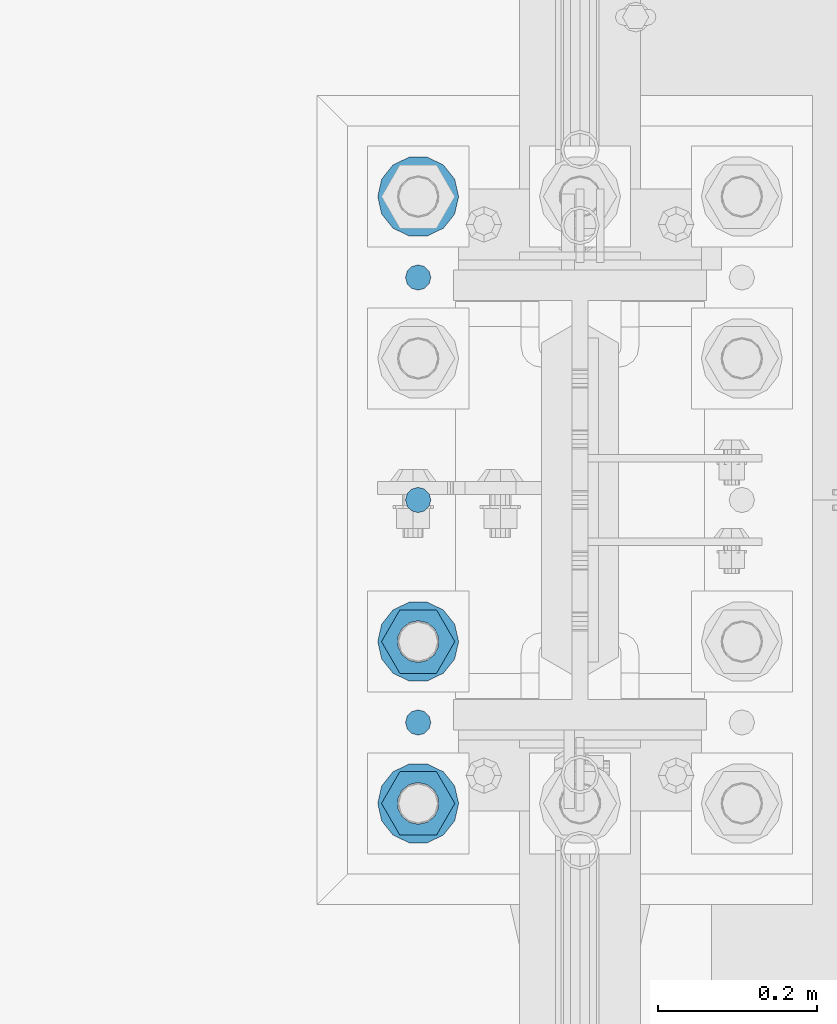
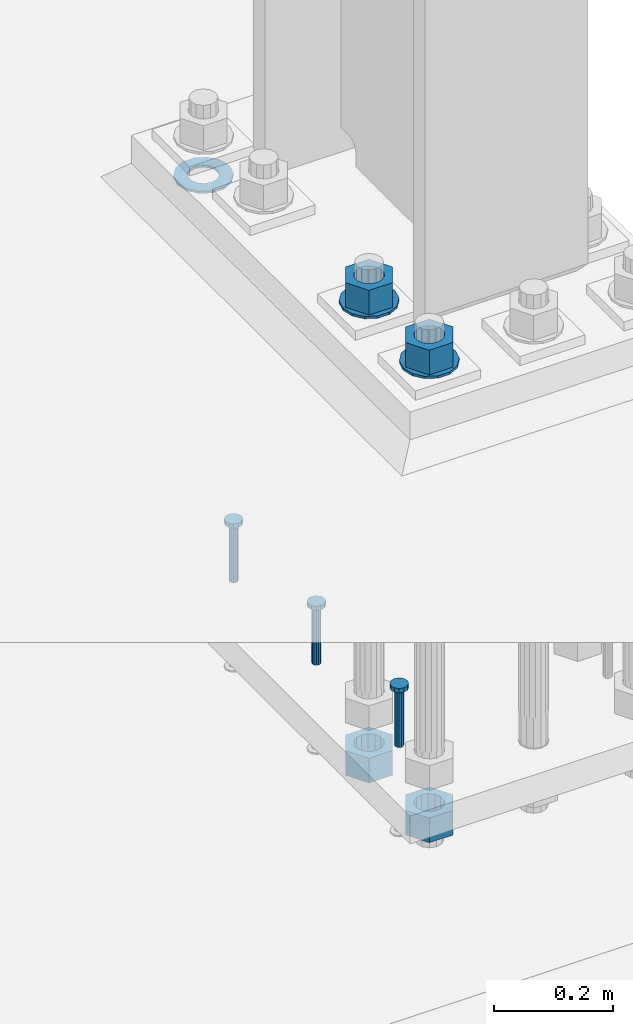
# One storey, part 849 of 1876: 10 columns, 1 element without a shape of its own.
"""IFC2X3 building model written with IfcOpenShell, lengths in millimetres."""

from ifc_helpers import new_model, si_unit, frame, origin_with_axes, place, context, subcontext, project, spatial, faceted_brep, material, type_object, element, aggregate, save


model = new_model("IFC2X3")

# Units and contexts
model_context = context("Model", 3, precision=1e-05, world=origin_with_axes())
body_context = subcontext(model_context, "Body", "Model", "MODEL_VIEW")
ifc_project = project(units=[si_unit("LENGTHUNIT", "METRE", prefix="MILLI"), si_unit("AREAUNIT", "SQUARE_METRE"), si_unit("VOLUMEUNIT", "CUBIC_METRE"), si_unit("MASSUNIT", "GRAM", prefix="KILO"), si_unit("TIMEUNIT", "SECOND"), si_unit("PLANEANGLEUNIT", "RADIAN"), si_unit("SOLIDANGLEUNIT", "STERADIAN"), si_unit("THERMODYNAMICTEMPERATUREUNIT", "DEGREE_CELSIUS"), si_unit("LUMINOUSINTENSITYUNIT", "LUMEN")], contexts=[model_context])

# Site, building, storey
site_placement = place(None, origin_with_axes())
site = spatial("IfcSite", under=ifc_project, at=site_placement, CompositionType="ELEMENT")
building_placement = place(site_placement, origin_with_axes())
building = spatial("IfcBuilding", under=site, at=building_placement, Name="Undefined", CompositionType="ELEMENT")
storey_placement = place(building_placement, origin_with_axes())
storey = spatial("IfcBuildingStorey", under=building, at=storey_placement, Name="Undefined", CompositionType="ELEMENT", Elevation=0.0)

# Assembly, columns
assembly_placement = place(storey_placement, origin_with_axes())
assembly = element("IfcElementAssembly", 1, at=assembly_placement, inside=storey, Name="TEMPLATE", AssemblyPlace="NOTDEFINED", PredefinedType="RIGID_FRAME")
ifc_material_1 = material(Name="STEEL/F436")
column_type_1 = type_object("IfcColumnType", Name="2_WASHER", PredefinedType="NOTDEFINED")
column_1_placement = place(assembly_placement, frame((7416.8, 8001.0, 38.1), z_axis=(0.0, -1.0, 0.0), x_axis=(0.0, 0.0, -1.0)))
column_1 = element("IfcColumn", 2, at=column_1_placement, type_object=column_type_1, material=ifc_material_1, Name="WASHER", ObjectType="2_WASHER", context=body_context, shape_type="Brep", body=[
    faceted_brep([(0.0, -50.7999992370605, 9.09494701772928e-13), (0.0, -45.7692178020588, -22.0412936161442), (4.7625, -45.7692178020588, -22.0412936161442), (4.7625, -50.7999992370605, 9.09494701772928e-13), (0.0, -31.6732814587394, -39.7170387128856), (4.7625, -31.6732814587394, -39.7170387128856), (0.0, -11.3040632752118, -49.5263371950259), (4.7625, -11.3040632752118, -49.5263371950259), (0.0, 11.30406327521, -49.5263371950264), (4.7625, 11.30406327521, -49.5263371950264), (0.0, 31.6732814587385, -39.7170387128867), (4.7625, 31.6732814587385, -39.7170387128867), (0.0, 45.7692178020579, -22.041293616146), (4.7625, 45.7692178020579, -22.041293616146), (0.0, 50.7999992370605, -9.09494701772928e-13), (4.7625, 50.7999992370605, -9.09494701772928e-13), (0.0, 45.7692178020588, 22.0412936161442), (4.7625, 45.7692178020588, 22.0412936161442), (0.0, 31.6732814587394, 39.7170387128856), (4.7625, 31.6732814587394, 39.7170387128856), (0.0, 11.3040632752118, 49.5263371950259), (4.7625, 11.3040632752118, 49.5263371950259), (0.0, -11.30406327521, 49.5263371950264), (4.7625, -11.30406327521, 49.5263371950264), (0.0, -31.6732814587385, 39.7170387128867), (4.7625, -31.6732814587385, 39.7170387128867), (0.0, -45.7692178020579, 22.041293616146), (4.7625, -45.7692178020579, 22.041293616146), (0.0, 0.0, 26.9869995117188), (0.0, 11.7093983825444, 24.3146012721213), (4.7625, 11.7093983825444, 24.3146012721213), (4.7625, 0.0, 26.9869995117188), (0.0, 21.0996520289491, 16.8262864224157), (4.7625, 21.0996520289491, 16.8262864224157), (0.0, 26.3108629296712, 6.00524193584533), (4.7625, 26.3108629296712, 6.00524193584533), (0.0, 26.3108629296712, -6.00524193584533), (4.7625, 26.3108629296712, -6.00524193584533), (0.0, 21.0996520289491, -16.8262864224157), (4.7625, 21.0996520289491, -16.8262864224157), (0.0, 11.7093983825444, -24.3146012721213), (4.7625, 11.7093983825444, -24.3146012721213), (0.0, 0.0, -26.9869995117188), (4.7625, 0.0, -26.9869995117188), (0.0, -11.7093983825444, -24.3146012721213), (4.7625, -11.7093983825444, -24.3146012721213), (0.0, -21.0996520289491, -16.8262864224157), (4.7625, -21.0996520289491, -16.8262864224157), (0.0, -26.3108629296712, -6.00524193584533), (4.7625, -26.3108629296712, -6.00524193584533), (0.0, -26.3108629296712, 6.00524193584533), (4.7625, -26.3108629296712, 6.00524193584533), (0.0, -21.0996520289491, 16.8262864224157), (4.7625, -21.0996520289491, 16.8262864224157), (0.0, -11.7093983825444, 24.3146012721213), (4.7625, -11.7093983825444, 24.3146012721213)], [[[0, 1, 2, 3]], [[1, 4, 5, 2]], [[4, 6, 7, 5]], [[6, 8, 9, 7]], [[8, 10, 11, 9]], [[10, 12, 13, 11]], [[12, 14, 15, 13]], [[14, 16, 17, 15]], [[16, 18, 19, 17]], [[18, 20, 21, 19]], [[20, 22, 23, 21]], [[22, 24, 25, 23]], [[24, 26, 27, 25]], [[26, 0, 3, 27]], [[28, 29, 30, 31]], [[29, 32, 33, 30]], [[32, 34, 35, 33]], [[34, 36, 37, 35]], [[36, 38, 39, 37]], [[38, 40, 41, 39]], [[40, 42, 43, 41]], [[42, 44, 45, 43]], [[44, 46, 47, 45]], [[46, 48, 49, 47]], [[48, 50, 51, 49]], [[50, 52, 53, 51]], [[52, 54, 55, 53]], [[54, 28, 31, 55]], [[5, 7, 9, 11, 13, 15, 17, 19, 21, 23, 25, 27, 3, 2], [33, 35, 37, 39, 41, 43, 45, 47, 49, 51, 53, 55, 31, 30]], [[26, 24, 22, 20, 18, 16, 14, 12, 10, 8, 6, 4, 1, 0], [54, 52, 50, 48, 46, 44, 42, 40, 38, 36, 34, 32, 29, 28]]]),
])
column_2_placement = place(assembly_placement, frame((7416.8, 7239.0, 119.0625), z_axis=(0.0, -1.0, 0.0), x_axis=(0.0, 0.0, -1.0)))
column_2 = element("IfcColumn", 3, at=column_2_placement, type_object=column_type_1, material=ifc_material_1, Name="WASHER", ObjectType="2_WASHER", context=body_context, shape_type="Brep", body=[
    faceted_brep([(0.0, -50.7999992370605, 9.09494701772928e-13), (0.0, -45.7692178020588, -22.0412936161442), (4.7625, -45.7692178020588, -22.0412936161442), (4.7625, -50.7999992370605, 9.09494701772928e-13), (0.0, -31.6732814587394, -39.7170387128856), (4.7625, -31.6732814587394, -39.7170387128856), (0.0, -11.3040632752118, -49.5263371950259), (4.7625, -11.3040632752118, -49.5263371950259), (0.0, 11.30406327521, -49.5263371950264), (4.7625, 11.30406327521, -49.5263371950264), (0.0, 31.6732814587385, -39.7170387128867), (4.7625, 31.6732814587385, -39.7170387128867), (0.0, 45.7692178020579, -22.041293616146), (4.7625, 45.7692178020579, -22.041293616146), (0.0, 50.7999992370605, -9.09494701772928e-13), (4.7625, 50.7999992370605, -9.09494701772928e-13), (0.0, 45.7692178020588, 22.0412936161442), (4.7625, 45.7692178020588, 22.0412936161442), (0.0, 31.6732814587394, 39.7170387128856), (4.7625, 31.6732814587394, 39.7170387128856), (0.0, 11.3040632752118, 49.5263371950259), (4.7625, 11.3040632752118, 49.5263371950259), (0.0, -11.30406327521, 49.5263371950264), (4.7625, -11.30406327521, 49.5263371950264), (0.0, -31.6732814587385, 39.7170387128867), (4.7625, -31.6732814587385, 39.7170387128867), (0.0, -45.7692178020579, 22.041293616146), (4.7625, -45.7692178020579, 22.041293616146), (0.0, 0.0, 26.9869995117188), (0.0, 11.7093983825444, 24.3146012721213), (4.7625, 11.7093983825444, 24.3146012721213), (4.7625, 0.0, 26.9869995117188), (0.0, 21.0996520289491, 16.8262864224157), (4.7625, 21.0996520289491, 16.8262864224157), (0.0, 26.3108629296712, 6.00524193584533), (4.7625, 26.3108629296712, 6.00524193584533), (0.0, 26.3108629296712, -6.00524193584533), (4.7625, 26.3108629296712, -6.00524193584533), (0.0, 21.0996520289491, -16.8262864224157), (4.7625, 21.0996520289491, -16.8262864224157), (0.0, 11.7093983825444, -24.3146012721213), (4.7625, 11.7093983825444, -24.3146012721213), (0.0, 0.0, -26.9869995117188), (4.7625, 0.0, -26.9869995117188), (0.0, -11.7093983825444, -24.3146012721213), (4.7625, -11.7093983825444, -24.3146012721213), (0.0, -21.0996520289491, -16.8262864224157), (4.7625, -21.0996520289491, -16.8262864224157), (0.0, -26.3108629296712, -6.00524193584533), (4.7625, -26.3108629296712, -6.00524193584533), (0.0, -26.3108629296712, 6.00524193584533), (4.7625, -26.3108629296712, 6.00524193584533), (0.0, -21.0996520289491, 16.8262864224157), (4.7625, -21.0996520289491, 16.8262864224157), (0.0, -11.7093983825444, 24.3146012721213), (4.7625, -11.7093983825444, 24.3146012721213)], [[[0, 1, 2, 3]], [[1, 4, 5, 2]], [[4, 6, 7, 5]], [[6, 8, 9, 7]], [[8, 10, 11, 9]], [[10, 12, 13, 11]], [[12, 14, 15, 13]], [[14, 16, 17, 15]], [[16, 18, 19, 17]], [[18, 20, 21, 19]], [[20, 22, 23, 21]], [[22, 24, 25, 23]], [[24, 26, 27, 25]], [[26, 0, 3, 27]], [[28, 29, 30, 31]], [[29, 32, 33, 30]], [[32, 34, 35, 33]], [[34, 36, 37, 35]], [[36, 38, 39, 37]], [[38, 40, 41, 39]], [[40, 42, 43, 41]], [[42, 44, 45, 43]], [[44, 46, 47, 45]], [[46, 48, 49, 47]], [[48, 50, 51, 49]], [[50, 52, 53, 51]], [[52, 54, 55, 53]], [[54, 28, 31, 55]], [[5, 7, 9, 11, 13, 15, 17, 19, 21, 23, 25, 27, 3, 2], [33, 35, 37, 39, 41, 43, 45, 47, 49, 51, 53, 55, 31, 30]], [[26, 24, 22, 20, 18, 16, 14, 12, 10, 8, 6, 4, 1, 0], [54, 52, 50, 48, 46, 44, 42, 40, 38, 36, 34, 32, 29, 28]]]),
])
column_3_placement = place(assembly_placement, frame((7416.8, 7442.2, 119.0625), z_axis=(0.0, -1.0, 0.0), x_axis=(0.0, 0.0, -1.0)))
column_3 = element("IfcColumn", 4, at=column_3_placement, type_object=column_type_1, material=ifc_material_1, Name="WASHER", ObjectType="2_WASHER", context=body_context, shape_type="Brep", body=[
    faceted_brep([(0.0, -50.7999992370605, 9.09494701772928e-13), (0.0, -45.7692178020588, -22.0412936161442), (4.7625, -45.7692178020588, -22.0412936161442), (4.7625, -50.7999992370605, 9.09494701772928e-13), (0.0, -31.6732814587394, -39.7170387128856), (4.7625, -31.6732814587394, -39.7170387128856), (0.0, -11.3040632752118, -49.5263371950259), (4.7625, -11.3040632752118, -49.5263371950259), (0.0, 11.30406327521, -49.5263371950264), (4.7625, 11.30406327521, -49.5263371950264), (0.0, 31.6732814587385, -39.7170387128867), (4.7625, 31.6732814587385, -39.7170387128867), (0.0, 45.7692178020579, -22.041293616146), (4.7625, 45.7692178020579, -22.041293616146), (0.0, 50.7999992370605, -9.09494701772928e-13), (4.7625, 50.7999992370605, -9.09494701772928e-13), (0.0, 45.7692178020588, 22.0412936161442), (4.7625, 45.7692178020588, 22.0412936161442), (0.0, 31.6732814587394, 39.7170387128856), (4.7625, 31.6732814587394, 39.7170387128856), (0.0, 11.3040632752118, 49.5263371950259), (4.7625, 11.3040632752118, 49.5263371950259), (0.0, -11.30406327521, 49.5263371950264), (4.7625, -11.30406327521, 49.5263371950264), (0.0, -31.6732814587385, 39.7170387128867), (4.7625, -31.6732814587385, 39.7170387128867), (0.0, -45.7692178020579, 22.041293616146), (4.7625, -45.7692178020579, 22.041293616146), (0.0, 0.0, 26.9869995117188), (0.0, 11.7093983825444, 24.3146012721213), (4.7625, 11.7093983825444, 24.3146012721213), (4.7625, 0.0, 26.9869995117188), (0.0, 21.0996520289491, 16.8262864224157), (4.7625, 21.0996520289491, 16.8262864224157), (0.0, 26.3108629296712, 6.00524193584533), (4.7625, 26.3108629296712, 6.00524193584533), (0.0, 26.3108629296712, -6.00524193584533), (4.7625, 26.3108629296712, -6.00524193584533), (0.0, 21.0996520289491, -16.8262864224157), (4.7625, 21.0996520289491, -16.8262864224157), (0.0, 11.7093983825444, -24.3146012721213), (4.7625, 11.7093983825444, -24.3146012721213), (0.0, 0.0, -26.9869995117188), (4.7625, 0.0, -26.9869995117188), (0.0, -11.7093983825444, -24.3146012721213), (4.7625, -11.7093983825444, -24.3146012721213), (0.0, -21.0996520289491, -16.8262864224157), (4.7625, -21.0996520289491, -16.8262864224157), (0.0, -26.3108629296712, -6.00524193584533), (4.7625, -26.3108629296712, -6.00524193584533), (0.0, -26.3108629296712, 6.00524193584533), (4.7625, -26.3108629296712, 6.00524193584533), (0.0, -21.0996520289491, 16.8262864224157), (4.7625, -21.0996520289491, 16.8262864224157), (0.0, -11.7093983825444, 24.3146012721213), (4.7625, -11.7093983825444, 24.3146012721213)], [[[0, 1, 2, 3]], [[1, 4, 5, 2]], [[4, 6, 7, 5]], [[6, 8, 9, 7]], [[8, 10, 11, 9]], [[10, 12, 13, 11]], [[12, 14, 15, 13]], [[14, 16, 17, 15]], [[16, 18, 19, 17]], [[18, 20, 21, 19]], [[20, 22, 23, 21]], [[22, 24, 25, 23]], [[24, 26, 27, 25]], [[26, 0, 3, 27]], [[28, 29, 30, 31]], [[29, 32, 33, 30]], [[32, 34, 35, 33]], [[34, 36, 37, 35]], [[36, 38, 39, 37]], [[38, 40, 41, 39]], [[40, 42, 43, 41]], [[42, 44, 45, 43]], [[44, 46, 47, 45]], [[46, 48, 49, 47]], [[48, 50, 51, 49]], [[50, 52, 53, 51]], [[52, 54, 55, 53]], [[54, 28, 31, 55]], [[5, 7, 9, 11, 13, 15, 17, 19, 21, 23, 25, 27, 3, 2], [33, 35, 37, 39, 41, 43, 45, 47, 49, 51, 53, 55, 31, 30]], [[26, 24, 22, 20, 18, 16, 14, 12, 10, 8, 6, 4, 1, 0], [54, 52, 50, 48, 46, 44, 42, 40, 38, 36, 34, 32, 29, 28]]]),
])
ifc_material_2 = material(Name="STEEL/A108")
column_type_2 = type_object("IfcColumnType", Name="5/8-DIA_HEADED ANCHOR STUD", PredefinedType="NOTDEFINED")
column_4_placement = place(assembly_placement, frame((7416.8, 7899.4, -736.6), z_axis=(1.0, 0.0, 0.0), x_axis=(0.0, 0.0, 1.0)))
column_4 = element("IfcColumn", 5, at=column_4_placement, type_object=column_type_2, material=ifc_material_2, Name="HEADED ANCHOR STUD", ObjectType="5/8-DIA_HEADED ANCHOR STUD", context=body_context, shape_type="Brep", body=[
    faceted_brep([(0.0, -7.94000005722046, 0.0), (0.0, -6.86999988555908, -3.97000002861023), (116.84, -6.86999988555908, -3.97000002861023), (116.84, -7.94000005722046, 0.0), (0.0, -3.97000002861023, -6.86999988555908), (116.84, -3.97000002861023, -6.86999988555908), (0.0, 0.0, -7.94000005722046), (116.84, 0.0, -7.94000005722046), (0.0, 3.97000002861023, -6.86999988555908), (116.84, 3.97000002861023, -6.86999988555908), (0.0, 6.86999988555908, -3.97000002861023), (116.84, 6.86999988555908, -3.97000002861023), (0.0, 7.94000005722046, 0.0), (116.84, 7.94000005722046, 0.0), (0.0, 6.86999988555908, 3.97000002861023), (116.84, 6.86999988555908, 3.97000002861023), (0.0, 3.97000002861023, 6.86999988555908), (116.84, 3.97000002861023, 6.86999988555908), (0.0, 0.0, 7.94000005722046), (116.84, 0.0, 7.94000005722046), (0.0, -3.97000002861023, 6.86999988555908), (116.84, -3.97000002861023, 6.86999988555908), (0.0, -6.86999988555908, 3.97000002861023), (116.84, -6.86999988555908, 3.97000002861023), (118.11, -13.75, -7.94000005722046), (118.11, -15.8800001144409, 0.0), (118.11, -7.94000005722046, -13.75), (118.11, 0.0, -15.8800001144409), (118.11, 7.94000005722046, -13.75), (118.11, 13.75, -7.94000005722046), (118.11, 15.8800001144409, 0.0), (118.11, 13.75, 7.94000005722046), (118.11, 7.94000005722046, 13.75), (118.11, 0.0, 15.8800001144409), (118.11, -7.94000005722046, 13.75), (118.11, -13.75, 7.94000005722046), (127.0, -13.75, -7.94000005722046), (127.0, -15.8800001144409, 0.0), (127.0, -7.94000005722046, -13.75), (127.0, 0.0, -15.8800001144409), (127.0, 7.94000005722046, -13.75), (127.0, 13.75, -7.94000005722046), (127.0, 15.8800001144409, 0.0), (127.0, 13.75, 7.94000005722046), (127.0, 7.94000005722046, 13.75), (127.0, 0.0, 15.8800001144409), (127.0, -7.94000005722046, 13.75), (127.0, -13.75, 7.94000005722046)], [[[0, 1, 2, 3]], [[1, 4, 5, 2]], [[4, 6, 7, 5]], [[6, 8, 9, 7]], [[8, 10, 11, 9]], [[10, 12, 13, 11]], [[12, 14, 15, 13]], [[14, 16, 17, 15]], [[16, 18, 19, 17]], [[18, 20, 21, 19]], [[20, 22, 23, 21]], [[22, 0, 3, 23]], [[22, 20, 18, 16, 14, 12, 10, 8, 6, 4, 1, 0]], [[3, 2, 24, 25]], [[2, 5, 26, 24]], [[5, 7, 27, 26]], [[7, 9, 28, 27]], [[9, 11, 29, 28]], [[11, 13, 30, 29]], [[13, 15, 31, 30]], [[15, 17, 32, 31]], [[17, 19, 33, 32]], [[19, 21, 34, 33]], [[21, 23, 35, 34]], [[23, 3, 25, 35]], [[25, 24, 36, 37]], [[24, 26, 38, 36]], [[26, 27, 39, 38]], [[27, 28, 40, 39]], [[28, 29, 41, 40]], [[29, 30, 42, 41]], [[30, 31, 43, 42]], [[31, 32, 44, 43]], [[32, 33, 45, 44]], [[33, 34, 46, 45]], [[34, 35, 47, 46]], [[35, 25, 37, 47]], [[38, 39, 40, 41, 42, 43, 44, 45, 46, 47, 37, 36]]]),
])
column_5_placement = place(assembly_placement, frame((7416.8, 7340.6, -736.6), z_axis=(1.0, 0.0, 0.0), x_axis=(0.0, 0.0, 1.0)))
column_5 = element("IfcColumn", 6, at=column_5_placement, type_object=column_type_2, material=ifc_material_2, Name="HEADED ANCHOR STUD", ObjectType="5/8-DIA_HEADED ANCHOR STUD", context=body_context, shape_type="Brep", body=[
    faceted_brep([(0.0, -7.94000005722046, 0.0), (0.0, -6.86999988555908, -3.97000002861023), (116.84, -6.86999988555908, -3.97000002861023), (116.84, -7.94000005722046, 0.0), (0.0, -3.97000002861023, -6.86999988555908), (116.84, -3.97000002861023, -6.86999988555908), (0.0, 0.0, -7.94000005722046), (116.84, 0.0, -7.94000005722046), (0.0, 3.97000002861023, -6.86999988555908), (116.84, 3.97000002861023, -6.86999988555908), (0.0, 6.86999988555908, -3.97000002861023), (116.84, 6.86999988555908, -3.97000002861023), (0.0, 7.94000005722046, 0.0), (116.84, 7.94000005722046, 0.0), (0.0, 6.86999988555908, 3.97000002861023), (116.84, 6.86999988555908, 3.97000002861023), (0.0, 3.97000002861023, 6.86999988555908), (116.84, 3.97000002861023, 6.86999988555908), (0.0, 0.0, 7.94000005722046), (116.84, 0.0, 7.94000005722046), (0.0, -3.97000002861023, 6.86999988555908), (116.84, -3.97000002861023, 6.86999988555908), (0.0, -6.86999988555908, 3.97000002861023), (116.84, -6.86999988555908, 3.97000002861023), (118.11, -13.75, -7.94000005722046), (118.11, -15.8800001144409, 0.0), (118.11, -7.94000005722046, -13.75), (118.11, 0.0, -15.8800001144409), (118.11, 7.94000005722046, -13.75), (118.11, 13.75, -7.94000005722046), (118.11, 15.8800001144409, 0.0), (118.11, 13.75, 7.94000005722046), (118.11, 7.94000005722046, 13.75), (118.11, 0.0, 15.8800001144409), (118.11, -7.94000005722046, 13.75), (118.11, -13.75, 7.94000005722046), (127.0, -13.75, -7.94000005722046), (127.0, -15.8800001144409, 0.0), (127.0, -7.94000005722046, -13.75), (127.0, 0.0, -15.8800001144409), (127.0, 7.94000005722046, -13.75), (127.0, 13.75, -7.94000005722046), (127.0, 15.8800001144409, 0.0), (127.0, 13.75, 7.94000005722046), (127.0, 7.94000005722046, 13.75), (127.0, 0.0, 15.8800001144409), (127.0, -7.94000005722046, 13.75), (127.0, -13.75, 7.94000005722046)], [[[0, 1, 2, 3]], [[1, 4, 5, 2]], [[4, 6, 7, 5]], [[6, 8, 9, 7]], [[8, 10, 11, 9]], [[10, 12, 13, 11]], [[12, 14, 15, 13]], [[14, 16, 17, 15]], [[16, 18, 19, 17]], [[18, 20, 21, 19]], [[20, 22, 23, 21]], [[22, 0, 3, 23]], [[22, 20, 18, 16, 14, 12, 10, 8, 6, 4, 1, 0]], [[3, 2, 24, 25]], [[2, 5, 26, 24]], [[5, 7, 27, 26]], [[7, 9, 28, 27]], [[9, 11, 29, 28]], [[11, 13, 30, 29]], [[13, 15, 31, 30]], [[15, 17, 32, 31]], [[17, 19, 33, 32]], [[19, 21, 34, 33]], [[21, 23, 35, 34]], [[23, 3, 25, 35]], [[25, 24, 36, 37]], [[24, 26, 38, 36]], [[26, 27, 39, 38]], [[27, 28, 40, 39]], [[28, 29, 41, 40]], [[29, 30, 42, 41]], [[30, 31, 43, 42]], [[31, 32, 44, 43]], [[32, 33, 45, 44]], [[33, 34, 46, 45]], [[34, 35, 47, 46]], [[35, 25, 37, 47]], [[38, 39, 40, 41, 42, 43, 44, 45, 46, 47, 37, 36]]]),
])
column_6_placement = place(assembly_placement, frame((7416.8, 7620.0, -736.6), z_axis=(1.0, 0.0, 0.0), x_axis=(0.0, 0.0, 1.0)))
column_6 = element("IfcColumn", 7, at=column_6_placement, type_object=column_type_2, material=ifc_material_2, Name="HEADED ANCHOR STUD", ObjectType="5/8-DIA_HEADED ANCHOR STUD", context=body_context, shape_type="Brep", body=[
    faceted_brep([(0.0, -7.94000005722046, 0.0), (0.0, -6.86999988555908, -3.97000002861023), (116.84, -6.86999988555908, -3.97000002861023), (116.84, -7.94000005722046, 0.0), (0.0, -3.97000002861023, -6.86999988555908), (116.84, -3.97000002861023, -6.86999988555908), (0.0, 0.0, -7.94000005722046), (116.84, 0.0, -7.94000005722046), (0.0, 3.97000002861023, -6.86999988555908), (116.84, 3.97000002861023, -6.86999988555908), (0.0, 6.86999988555908, -3.97000002861023), (116.84, 6.86999988555908, -3.97000002861023), (0.0, 7.94000005722046, 0.0), (116.84, 7.94000005722046, 0.0), (0.0, 6.86999988555908, 3.97000002861023), (116.84, 6.86999988555908, 3.97000002861023), (0.0, 3.97000002861023, 6.86999988555908), (116.84, 3.97000002861023, 6.86999988555908), (0.0, 0.0, 7.94000005722046), (116.84, 0.0, 7.94000005722046), (0.0, -3.97000002861023, 6.86999988555908), (116.84, -3.97000002861023, 6.86999988555908), (0.0, -6.86999988555908, 3.97000002861023), (116.84, -6.86999988555908, 3.97000002861023), (118.11, -13.75, -7.94000005722046), (118.11, -15.8800001144409, 0.0), (118.11, -7.94000005722046, -13.75), (118.11, 0.0, -15.8800001144409), (118.11, 7.94000005722046, -13.75), (118.11, 13.75, -7.94000005722046), (118.11, 15.8800001144409, 0.0), (118.11, 13.75, 7.94000005722046), (118.11, 7.94000005722046, 13.75), (118.11, 0.0, 15.8800001144409), (118.11, -7.94000005722046, 13.75), (118.11, -13.75, 7.94000005722046), (127.0, -13.75, -7.94000005722046), (127.0, -15.8800001144409, 0.0), (127.0, -7.94000005722046, -13.75), (127.0, 0.0, -15.8800001144409), (127.0, 7.94000005722046, -13.75), (127.0, 13.75, -7.94000005722046), (127.0, 15.8800001144409, 0.0), (127.0, 13.75, 7.94000005722046), (127.0, 7.94000005722046, 13.75), (127.0, 0.0, 15.8800001144409), (127.0, -7.94000005722046, 13.75), (127.0, -13.75, 7.94000005722046)], [[[0, 1, 2, 3]], [[1, 4, 5, 2]], [[4, 6, 7, 5]], [[6, 8, 9, 7]], [[8, 10, 11, 9]], [[10, 12, 13, 11]], [[12, 14, 15, 13]], [[14, 16, 17, 15]], [[16, 18, 19, 17]], [[18, 20, 21, 19]], [[20, 22, 23, 21]], [[22, 0, 3, 23]], [[22, 20, 18, 16, 14, 12, 10, 8, 6, 4, 1, 0]], [[3, 2, 24, 25]], [[2, 5, 26, 24]], [[5, 7, 27, 26]], [[7, 9, 28, 27]], [[9, 11, 29, 28]], [[11, 13, 30, 29]], [[13, 15, 31, 30]], [[15, 17, 32, 31]], [[17, 19, 33, 32]], [[19, 21, 34, 33]], [[21, 23, 35, 34]], [[23, 3, 25, 35]], [[25, 24, 36, 37]], [[24, 26, 38, 36]], [[26, 27, 39, 38]], [[27, 28, 40, 39]], [[28, 29, 41, 40]], [[29, 30, 42, 41]], [[30, 31, 43, 42]], [[31, 32, 44, 43]], [[32, 33, 45, 44]], [[33, 34, 46, 45]], [[34, 35, 47, 46]], [[35, 25, 37, 47]], [[38, 39, 40, 41, 42, 43, 44, 45, 46, 47, 37, 36]]]),
])
ifc_material_3 = material(Name="STEEL/A563")
column_type_3 = type_object("IfcColumnType", Name="2_HEAVY_HEX_NUT", PredefinedType="NOTDEFINED")
column_7_placement = place(assembly_placement, frame((7416.8, 7239.0, 169.8625), z_axis=(0.0, -1.0, 0.0), x_axis=(0.0, 0.0, -1.0)))
column_7 = element("IfcColumn", 8, at=column_7_placement, type_object=column_type_3, material=ifc_material_3, Name="NUT", ObjectType="2_HEAVY_HEX_NUT", context=body_context, shape_type="Brep", body=[
    faceted_brep([(0.0, -46.0369987487793, 9.09494701772928e-13), (0.0, -23.0184993743896, -39.869213104248), (50.8, -23.0184993743896, -39.869213104248), (50.8, -46.0369987487793, 9.09494701772928e-13), (0.0, 23.0184993743896, -39.869213104248), (50.8, 23.0184993743896, -39.869213104248), (0.0, 46.0369987487793, -9.09494701772928e-13), (50.8, 46.0369987487793, -9.09494701772928e-13), (0.0, 23.0184993743896, 39.869213104248), (50.8, 23.0184993743896, 39.869213104248), (0.0, -23.0184993743896, 39.869213104248), (50.8, -23.0184993743896, 39.869213104248), (0.0, 0.0, 26.1940002441406), (0.0, 11.3650617044514, 23.5999013092769), (50.8, 11.3650617044513, 23.5999013092771), (50.8, 0.0, 26.1940002441406), (0.0, 20.4791109456437, 16.3316083006703), (50.8, 20.4791109456439, 16.3316083006703), (0.0, 25.5370200498346, 5.82867859874477), (50.8, 25.5370200498343, 5.82867859874455), (0.0, 25.5370200498346, -5.82867859874477), (50.8, 25.5370200498343, -5.82867859874455), (0.0, 20.4791109456437, -16.3316083006703), (50.8, 20.4791109456439, -16.3316083006703), (0.0, 11.3650617044514, -23.5999013092769), (50.8, 11.3650617044514, -23.5999013092771), (0.0, 0.0, -26.1940002441406), (50.8, 0.0, -26.1940002441406), (0.0, -11.3650617044514, -23.5999013092769), (50.8, -11.3650617044513, -23.5999013092771), (0.0, -20.4791109456437, -16.3316083006703), (50.8, -20.4791109456439, -16.3316083006703), (0.0, -25.5370200498346, -5.82867859874477), (50.8, -25.5370200498343, -5.82867859874455), (0.0, -25.5370200498346, 5.82867859874477), (50.8, -25.5370200498343, 5.82867859874455), (0.0, -20.4791109456437, 16.3316083006703), (50.8, -20.4791109456439, 16.3316083006703), (0.0, -11.3650617044514, 23.5999013092769), (50.8, -11.3650617044514, 23.5999013092771)], [[[0, 1, 2, 3]], [[1, 4, 5, 2]], [[4, 6, 7, 5]], [[6, 8, 9, 7]], [[8, 10, 11, 9]], [[10, 0, 3, 11]], [[12, 13, 14, 15]], [[13, 16, 17, 14]], [[16, 18, 19, 17]], [[18, 20, 21, 19]], [[20, 22, 23, 21]], [[22, 24, 25, 23]], [[24, 26, 27, 25]], [[26, 28, 29, 27]], [[28, 30, 31, 29]], [[30, 32, 33, 31]], [[32, 34, 35, 33]], [[34, 36, 37, 35]], [[36, 38, 39, 37]], [[38, 12, 15, 39]], [[5, 7, 9, 11, 3, 2], [17, 19, 21, 23, 25, 27, 29, 31, 33, 35, 37, 39, 15, 14]], [[10, 8, 6, 4, 1, 0], [38, 36, 34, 32, 30, 28, 26, 24, 22, 20, 18, 16, 13, 12]]]),
])
column_8_placement = place(assembly_placement, frame((7416.8, 7239.0, -793.75), z_axis=(0.0, -1.0, 0.0), x_axis=(0.0, 0.0, -1.0)))
column_8 = element("IfcColumn", 9, at=column_8_placement, type_object=column_type_3, material=ifc_material_3, Name="NUT", ObjectType="2_HEAVY_HEX_NUT", context=body_context, shape_type="Brep", body=[
    faceted_brep([(0.0, -46.0369987487793, 9.09494701772928e-13), (0.0, -23.0184993743896, -39.869213104248), (50.8, -23.0184993743896, -39.869213104248), (50.8, -46.0369987487793, 9.09494701772928e-13), (0.0, 23.0184993743896, -39.869213104248), (50.8, 23.0184993743896, -39.869213104248), (0.0, 46.0369987487793, -9.09494701772928e-13), (50.8, 46.0369987487793, -9.09494701772928e-13), (0.0, 23.0184993743896, 39.869213104248), (50.8, 23.0184993743896, 39.869213104248), (0.0, -23.0184993743896, 39.869213104248), (50.8, -23.0184993743896, 39.869213104248), (0.0, 0.0, 26.1940002441406), (0.0, 11.3650617044514, 23.5999013092769), (50.8, 11.3650617044513, 23.5999013092771), (50.8, 0.0, 26.1940002441406), (0.0, 20.4791109456437, 16.3316083006703), (50.8, 20.4791109456439, 16.3316083006703), (0.0, 25.5370200498346, 5.82867859874477), (50.8, 25.5370200498343, 5.82867859874455), (0.0, 25.5370200498346, -5.82867859874477), (50.8, 25.5370200498343, -5.82867859874455), (0.0, 20.4791109456437, -16.3316083006703), (50.8, 20.4791109456439, -16.3316083006703), (0.0, 11.3650617044514, -23.5999013092769), (50.8, 11.3650617044514, -23.5999013092771), (0.0, 0.0, -26.1940002441406), (50.8, 0.0, -26.1940002441406), (0.0, -11.3650617044514, -23.5999013092769), (50.8, -11.3650617044513, -23.5999013092771), (0.0, -20.4791109456437, -16.3316083006703), (50.8, -20.4791109456439, -16.3316083006703), (0.0, -25.5370200498346, -5.82867859874477), (50.8, -25.5370200498343, -5.82867859874455), (0.0, -25.5370200498346, 5.82867859874477), (50.8, -25.5370200498343, 5.82867859874455), (0.0, -20.4791109456437, 16.3316083006703), (50.8, -20.4791109456439, 16.3316083006703), (0.0, -11.3650617044514, 23.5999013092769), (50.8, -11.3650617044514, 23.5999013092771)], [[[0, 1, 2, 3]], [[1, 4, 5, 2]], [[4, 6, 7, 5]], [[6, 8, 9, 7]], [[8, 10, 11, 9]], [[10, 0, 3, 11]], [[12, 13, 14, 15]], [[13, 16, 17, 14]], [[16, 18, 19, 17]], [[18, 20, 21, 19]], [[20, 22, 23, 21]], [[22, 24, 25, 23]], [[24, 26, 27, 25]], [[26, 28, 29, 27]], [[28, 30, 31, 29]], [[30, 32, 33, 31]], [[32, 34, 35, 33]], [[34, 36, 37, 35]], [[36, 38, 39, 37]], [[38, 12, 15, 39]], [[5, 7, 9, 11, 3, 2], [17, 19, 21, 23, 25, 27, 29, 31, 33, 35, 37, 39, 15, 14]], [[10, 8, 6, 4, 1, 0], [38, 36, 34, 32, 30, 28, 26, 24, 22, 20, 18, 16, 13, 12]]]),
])
column_9_placement = place(assembly_placement, frame((7416.8, 7442.2, 169.8625), z_axis=(0.0, -1.0, 0.0), x_axis=(0.0, 0.0, -1.0)))
column_9 = element("IfcColumn", 10, at=column_9_placement, type_object=column_type_3, material=ifc_material_3, Name="NUT", ObjectType="2_HEAVY_HEX_NUT", context=body_context, shape_type="Brep", body=[
    faceted_brep([(0.0, -46.0369987487793, 9.09494701772928e-13), (0.0, -23.0184993743896, -39.869213104248), (50.8, -23.0184993743896, -39.869213104248), (50.8, -46.0369987487793, 9.09494701772928e-13), (0.0, 23.0184993743896, -39.869213104248), (50.8, 23.0184993743896, -39.869213104248), (0.0, 46.0369987487793, -9.09494701772928e-13), (50.8, 46.0369987487793, -9.09494701772928e-13), (0.0, 23.0184993743896, 39.869213104248), (50.8, 23.0184993743896, 39.869213104248), (0.0, -23.0184993743896, 39.869213104248), (50.8, -23.0184993743896, 39.869213104248), (0.0, 0.0, 26.1940002441406), (0.0, 11.3650617044514, 23.5999013092769), (50.8, 11.3650617044513, 23.5999013092771), (50.8, 0.0, 26.1940002441406), (0.0, 20.4791109456437, 16.3316083006703), (50.8, 20.4791109456439, 16.3316083006703), (0.0, 25.5370200498346, 5.82867859874477), (50.8, 25.5370200498343, 5.82867859874455), (0.0, 25.5370200498346, -5.82867859874477), (50.8, 25.5370200498343, -5.82867859874455), (0.0, 20.4791109456437, -16.3316083006703), (50.8, 20.4791109456439, -16.3316083006703), (0.0, 11.3650617044514, -23.5999013092769), (50.8, 11.3650617044514, -23.5999013092771), (0.0, 0.0, -26.1940002441406), (50.8, 0.0, -26.1940002441406), (0.0, -11.3650617044514, -23.5999013092769), (50.8, -11.3650617044513, -23.5999013092771), (0.0, -20.4791109456437, -16.3316083006703), (50.8, -20.4791109456439, -16.3316083006703), (0.0, -25.5370200498346, -5.82867859874477), (50.8, -25.5370200498343, -5.82867859874455), (0.0, -25.5370200498346, 5.82867859874477), (50.8, -25.5370200498343, 5.82867859874455), (0.0, -20.4791109456437, 16.3316083006703), (50.8, -20.4791109456439, 16.3316083006703), (0.0, -11.3650617044514, 23.5999013092769), (50.8, -11.3650617044514, 23.5999013092771)], [[[0, 1, 2, 3]], [[1, 4, 5, 2]], [[4, 6, 7, 5]], [[6, 8, 9, 7]], [[8, 10, 11, 9]], [[10, 0, 3, 11]], [[12, 13, 14, 15]], [[13, 16, 17, 14]], [[16, 18, 19, 17]], [[18, 20, 21, 19]], [[20, 22, 23, 21]], [[22, 24, 25, 23]], [[24, 26, 27, 25]], [[26, 28, 29, 27]], [[28, 30, 31, 29]], [[30, 32, 33, 31]], [[32, 34, 35, 33]], [[34, 36, 37, 35]], [[36, 38, 39, 37]], [[38, 12, 15, 39]], [[5, 7, 9, 11, 3, 2], [17, 19, 21, 23, 25, 27, 29, 31, 33, 35, 37, 39, 15, 14]], [[10, 8, 6, 4, 1, 0], [38, 36, 34, 32, 30, 28, 26, 24, 22, 20, 18, 16, 13, 12]]]),
])
column_10_placement = place(assembly_placement, frame((7416.8, 7442.2, -793.75), z_axis=(0.0, -1.0, 0.0), x_axis=(0.0, 0.0, -1.0)))
column_10 = element("IfcColumn", 11, at=column_10_placement, type_object=column_type_3, material=ifc_material_3, Name="NUT", ObjectType="2_HEAVY_HEX_NUT", context=body_context, shape_type="Brep", body=[
    faceted_brep([(0.0, -46.0369987487793, 9.09494701772928e-13), (0.0, -23.0184993743896, -39.869213104248), (50.8, -23.0184993743896, -39.869213104248), (50.8, -46.0369987487793, 9.09494701772928e-13), (0.0, 23.0184993743896, -39.869213104248), (50.8, 23.0184993743896, -39.869213104248), (0.0, 46.0369987487793, -9.09494701772928e-13), (50.8, 46.0369987487793, -9.09494701772928e-13), (0.0, 23.0184993743896, 39.869213104248), (50.8, 23.0184993743896, 39.869213104248), (0.0, -23.0184993743896, 39.869213104248), (50.8, -23.0184993743896, 39.869213104248), (0.0, 0.0, 26.1940002441406), (0.0, 11.3650617044514, 23.5999013092769), (50.8, 11.3650617044513, 23.5999013092771), (50.8, 0.0, 26.1940002441406), (0.0, 20.4791109456437, 16.3316083006703), (50.8, 20.4791109456439, 16.3316083006703), (0.0, 25.5370200498346, 5.82867859874477), (50.8, 25.5370200498343, 5.82867859874455), (0.0, 25.5370200498346, -5.82867859874477), (50.8, 25.5370200498343, -5.82867859874455), (0.0, 20.4791109456437, -16.3316083006703), (50.8, 20.4791109456439, -16.3316083006703), (0.0, 11.3650617044514, -23.5999013092769), (50.8, 11.3650617044514, -23.5999013092771), (0.0, 0.0, -26.1940002441406), (50.8, 0.0, -26.1940002441406), (0.0, -11.3650617044514, -23.5999013092769), (50.8, -11.3650617044513, -23.5999013092771), (0.0, -20.4791109456437, -16.3316083006703), (50.8, -20.4791109456439, -16.3316083006703), (0.0, -25.5370200498346, -5.82867859874477), (50.8, -25.5370200498343, -5.82867859874455), (0.0, -25.5370200498346, 5.82867859874477), (50.8, -25.5370200498343, 5.82867859874455), (0.0, -20.4791109456437, 16.3316083006703), (50.8, -20.4791109456439, 16.3316083006703), (0.0, -11.3650617044514, 23.5999013092769), (50.8, -11.3650617044514, 23.5999013092771)], [[[0, 1, 2, 3]], [[1, 4, 5, 2]], [[4, 6, 7, 5]], [[6, 8, 9, 7]], [[8, 10, 11, 9]], [[10, 0, 3, 11]], [[12, 13, 14, 15]], [[13, 16, 17, 14]], [[16, 18, 19, 17]], [[18, 20, 21, 19]], [[20, 22, 23, 21]], [[22, 24, 25, 23]], [[24, 26, 27, 25]], [[26, 28, 29, 27]], [[28, 30, 31, 29]], [[30, 32, 33, 31]], [[32, 34, 35, 33]], [[34, 36, 37, 35]], [[36, 38, 39, 37]], [[38, 12, 15, 39]], [[5, 7, 9, 11, 3, 2], [17, 19, 21, 23, 25, 27, 29, 31, 33, 35, 37, 39, 15, 14]], [[10, 8, 6, 4, 1, 0], [38, 36, 34, 32, 30, 28, 26, 24, 22, 20, 18, 16, 13, 12]]]),
])
aggregate(assembly, [column_1, column_4, column_5, column_6, column_7, column_2, column_8, column_9, column_3, column_10])

save(model, "model.ifc")
